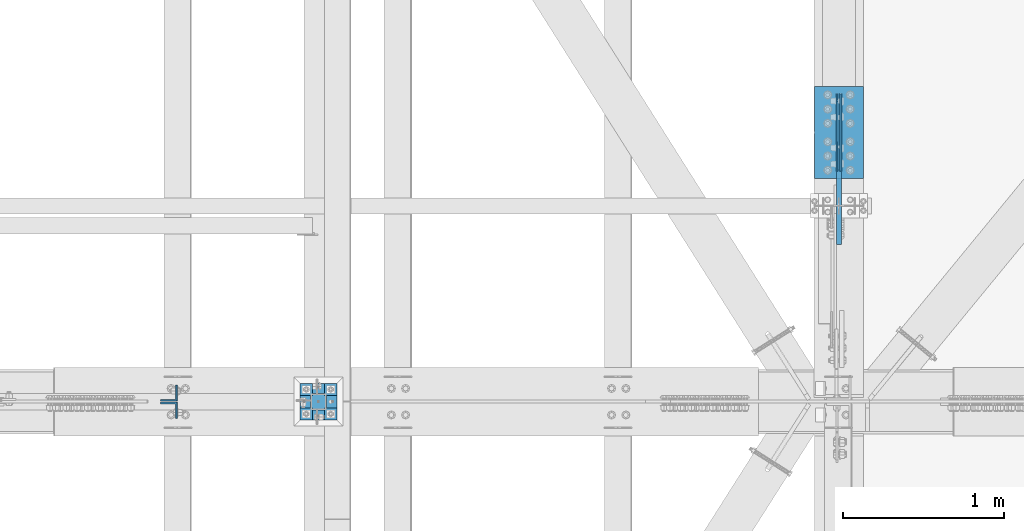
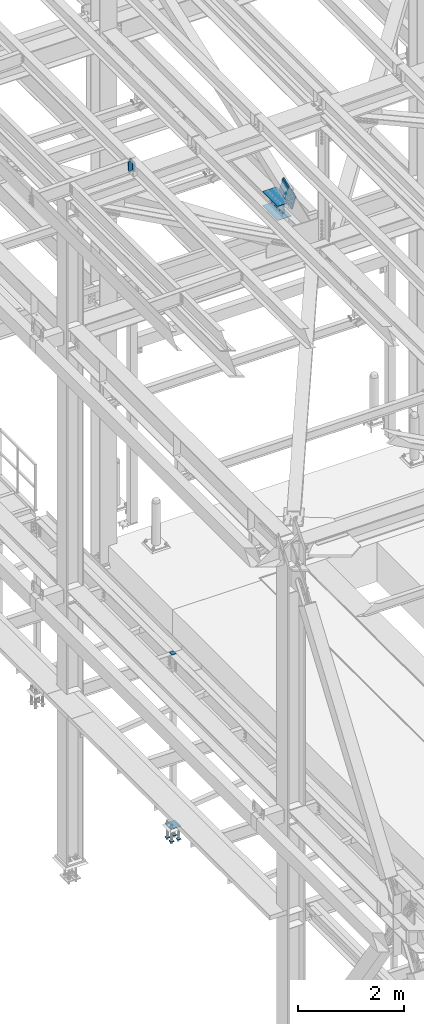
# One storey, part 2405 of 3843: 10 beams, 3 members, 5 elements without a shape of their own.
"""IFC2X3 building model written with IfcOpenShell, lengths in millimetres."""

from ifc_helpers import new_model, si_unit, frame, origin_with_axes, place, context, subcontext, project, spatial, faceted_brep, material, type_object, element, aggregate, save


model = new_model("IFC2X3")

# Units and contexts
model_context = context("Model", 3, precision=1e-05, world=origin_with_axes())
body_context = subcontext(model_context, "Body", "Model", "MODEL_VIEW")
ifc_project = project(units=[si_unit("LENGTHUNIT", "METRE", prefix="MILLI"), si_unit("AREAUNIT", "SQUARE_METRE"), si_unit("VOLUMEUNIT", "CUBIC_METRE"), si_unit("MASSUNIT", "GRAM", prefix="KILO"), si_unit("TIMEUNIT", "SECOND"), si_unit("PLANEANGLEUNIT", "RADIAN"), si_unit("SOLIDANGLEUNIT", "STERADIAN"), si_unit("THERMODYNAMICTEMPERATUREUNIT", "DEGREE_CELSIUS"), si_unit("LUMINOUSINTENSITYUNIT", "LUMEN")], contexts=[model_context])

# Site, building, storey
site_placement = place(None, origin_with_axes())
site = spatial("IfcSite", under=ifc_project, at=site_placement, CompositionType="ELEMENT")
building_placement = place(site_placement, origin_with_axes())
building = spatial("IfcBuilding", under=site, at=building_placement, Name="Undefined", CompositionType="ELEMENT")
storey_placement = place(building_placement, origin_with_axes())
storey = spatial("IfcBuildingStorey", under=building, at=storey_placement, Name="Undefined", CompositionType="ELEMENT", Elevation=0.0)

# Assembly, members
assembly_1_placement = place(storey_placement, origin_with_axes())
assembly_1 = element("IfcElementAssembly", 1, at=assembly_1_placement, inside=storey, Name="BEAM", AssemblyPlace="NOTDEFINED", PredefinedType="RIGID_FRAME")
ifc_material = material(Name="STEEL/A572-50")
member_type_1 = type_object("IfcMemberType", Name="L4X4X3/8", PredefinedType="NOTDEFINED")
member_1_placement = place(assembly_1_placement, frame((37892.6968642126, 84039.0749999523, 45491.3538421112), z_axis=(0.0, 1.0, 0.0), x_axis=(-0.0211520980073474, 0.0, 0.999776269347241)))
member_1 = element("IfcMember", 2, at=member_1_placement, type_object=member_type_1, material=ifc_material, Name="ANGLE", ObjectType="L4X4X3/8", context=body_context, shape_type="Brep", body=[
    faceted_brep([(0.0, 50.8000000000029, -50.8000000000029), (0.0, 50.8000000000029, 50.8000000000029), (228.599999994367, 50.7999999996973, 50.8000000000029), (228.599999994367, 50.7999999996973, -50.8000000000029), (0.0, 41.2750000000015, 50.8000000000029), (228.599999994345, 41.2749999997031, 50.8000000000029), (0.0, 41.2749999999942, -41.2750000000015), (228.599999994345, 41.2749999997031, -41.2750000000015), (0.0, -50.8000000000029, -41.2750000000015), (228.599999994258, -50.8000000001412, -41.2750000000015), (0.0, -50.8000000000029, -50.8000000000029), (228.599999994258, -50.8000000001412, -50.8000000000029)], [[[0, 1, 2, 3]], [[1, 4, 5, 2]], [[4, 6, 7, 5]], [[6, 8, 9, 7]], [[8, 10, 11, 9]], [[10, 0, 3, 11]], [[5, 7, 9, 11, 3, 2]], [[10, 8, 6, 4, 1, 0]]]),
])
member_2_placement = place(assembly_1_placement, frame((37887.8614946073, 83931.1250000477, 45719.9026972787), z_axis=(0.0, -1.0, 0.0), x_axis=(0.0211520550054438, 0.0, -0.999776270257025)))
member_2 = element("IfcMember", 3, at=member_2_placement, type_object=member_type_1, material=ifc_material, Name="ANGLE", ObjectType="L4X4X3/8", context=body_context, shape_type="Brep", body=[
    faceted_brep([(0.0, 50.8000000000029, -50.8000000000029), (0.0, 50.8000000000029, 50.8000000000029), (228.599999994367, 50.7999999996973, 50.8000000000029), (228.599999994367, 50.7999999996973, -50.8000000000029), (0.0, 41.2750000000015, 50.8000000000029), (228.599999994345, 41.2749999997031, 50.8000000000029), (0.0, 41.2749999999942, -41.2750000000015), (228.599999994345, 41.2749999997031, -41.2750000000015), (0.0, -50.8000000000029, -41.2750000000015), (228.599999994258, -50.8000000001412, -41.2750000000015), (0.0, -50.8000000000029, -50.8000000000029), (228.599999994258, -50.8000000001412, -50.8000000000029)], [[[0, 1, 2, 3]], [[1, 4, 5, 2]], [[4, 6, 7, 5]], [[6, 8, 9, 7]], [[8, 10, 11, 9]], [[10, 0, 3, 11]], [[5, 7, 9, 11, 3, 2]], [[10, 8, 6, 4, 1, 0]]]),
])
aggregate(assembly_1, [member_1, member_2])

# Assembly, beams
assembly_2_placement = place(storey_placement, origin_with_axes())
assembly_2 = element("IfcElementAssembly", 4, at=assembly_2_placement, inside=storey, Name="BEAM", AssemblyPlace="NOTDEFINED", PredefinedType="RIGID_FRAME")
beam_type_1 = type_object("IfcBeamType", PredefinedType="NOTDEFINED")
beam_1_placement = place(assembly_2_placement, frame((42073.5125, 85420.2000125336, 42248.7356111364), z_axis=(0.0, 0.000321673000085866, 0.999999948263239), x_axis=(0.0, 0.999999948263239, -0.000321673000078448)))
beam_1 = element("IfcBeam", 5, at=beam_1_placement, type_object=beam_type_1, material=ifc_material, Name="PLATE", context=body_context, shape_type="Brep", body=[
    faceted_brep([(-4.65661287307739e-10, 4.76249999999709, -88.9000000002779), (0.0, 4.76249999999709, 88.9000015258789), (482.600000007384, 4.76249999999709, 88.9000000010856), (482.60000000638, 4.76249999999709, -88.8999999994776), (0.0, -4.76249999999709, 88.9000015258789), (482.600000007384, -4.76249999999709, 88.9000000010856), (-4.65661287307739e-10, -4.76249999999709, -88.9000000002779), (482.60000000638, -4.76249999999709, -88.8999999994776)], [[[0, 1, 2, 3]], [[1, 4, 5, 2]], [[4, 6, 7, 5]], [[6, 0, 3, 7]], [[5, 7, 3, 2]], [[6, 4, 1, 0]]]),
])
beam_2_placement = place(assembly_2_placement, frame((42051.2875, 85420.2000125336, 42248.7356111364), z_axis=(0.0, 0.000321673000085866, 0.999999948263239), x_axis=(0.0, 0.999999948263239, -0.000321673000078448)))
beam_2 = element("IfcBeam", 6, at=beam_2_placement, type_object=beam_type_1, material=ifc_material, Name="PLATE", context=body_context, shape_type="Brep", body=[
    faceted_brep([(-4.65661287307739e-10, 4.76249999999709, -88.9000000002779), (0.0, 4.76249999999709, 88.9000015258789), (482.600000007384, 4.76249999999709, 88.9000000010856), (482.60000000638, 4.76249999999709, -88.8999999994776), (0.0, -4.76249999999709, 88.9000015258789), (482.600000007384, -4.76249999999709, 88.9000000010856), (-4.65661287307739e-10, -4.76249999999709, -88.9000000002779), (482.60000000638, -4.76249999999709, -88.8999999994776)], [[[0, 1, 2, 3]], [[1, 4, 5, 2]], [[4, 6, 7, 5]], [[6, 0, 3, 7]], [[5, 7, 3, 2]], [[6, 4, 1, 0]]]),
])
beam_type_2 = type_object("IfcBeamType", PredefinedType="NOTDEFINED")
beam_3_placement = place(assembly_2_placement, frame((42062.4, 85375.6979279318, 42086.8249178814), z_axis=(1.0, 0.0, 0.0), x_axis=(0.0, 0.999999948263239, -0.000321673000078448)))
beam_3 = element("IfcBeam", 7, at=beam_3_placement, type_object=beam_type_2, material=ifc_material, Name="PLATE", context=body_context, shape_type="Brep", body=[
    faceted_brep([(2.91038304567337e-11, 4.76250000001892, -152.400000000001), (2.91038304567337e-11, 4.76250000001892, 152.400000000001), (571.500000008222, 4.76250000096479, 152.400000000001), (571.500000008222, 4.76250000096479, -152.400000000001), (-2.91038304567337e-11, -4.76250000001164, 152.400000000001), (571.500000008164, -4.76249999906577, 152.400000000001), (-2.91038304567337e-11, -4.76250000001164, -152.400000000001), (571.500000008164, -4.76249999906577, -152.400000000001)], [[[0, 1, 2, 3]], [[1, 4, 5, 2]], [[4, 6, 7, 5]], [[6, 0, 3, 7]], [[5, 7, 3, 2]], [[6, 4, 1, 0]]]),
])
beam_4_placement = place(assembly_2_placement, frame((42062.4, 85375.8021017318, 42410.6749011208), z_axis=(1.0, 0.0, 0.0), x_axis=(0.0, 0.999999948263239, -0.000321673000078448)))
beam_4 = element("IfcBeam", 8, at=beam_4_placement, type_object=beam_type_2, material=ifc_material, Name="PLATE", context=body_context, shape_type="Brep", body=[
    faceted_brep([(2.91038304567337e-11, 4.76250000001892, -152.400000000001), (2.91038304567337e-11, 4.76250000001892, 152.400000000001), (571.500000008222, 4.76250000096479, 152.400000000001), (571.500000008222, 4.76250000096479, -152.400000000001), (-2.91038304567337e-11, -4.76250000001164, 152.400000000001), (571.500000008164, -4.76249999906577, 152.400000000001), (-2.91038304567337e-11, -4.76250000001164, -152.400000000001), (571.500000008164, -4.76249999906577, -152.400000000001)], [[[0, 1, 2, 3]], [[1, 4, 5, 2]], [[4, 6, 7, 5]], [[6, 0, 3, 7]], [[5, 7, 3, 2]], [[6, 4, 1, 0]]]),
])
aggregate(assembly_2, [beam_1, beam_3, beam_4, beam_2])

# Assembly, member
assembly_3_placement = place(storey_placement, origin_with_axes())
assembly_3 = element("IfcElementAssembly", 9, at=assembly_3_placement, inside=storey, AssemblyPlace="NOTDEFINED", PredefinedType="RIGID_FRAME")
member_type_2 = type_object("IfcMemberType", PredefinedType="NOTDEFINED")
member_3_placement = place(assembly_3_placement, frame((42062.4, 85030.1293786808, 42641.7074003114), z_axis=(0.0, 0.351612257950095, -0.936145725867098), x_axis=(0.0, 0.936145725867102, 0.351612257950085)))
member_3 = element("IfcMember", 10, at=member_3_placement, type_object=member_type_2, material=ifc_material, Name="PLATE", context=body_context, shape_type="Brep", body=[
    faceted_brep([(3.56521923094988e-10, 15.875, -190.500000000146), (-3.61978891305625e-10, 15.875, 190.500000000153), (495.299999995012, 15.875, 190.500000001084), (495.299999995726, 15.875, -190.499999999221), (-3.61978891305625e-10, -15.875, 190.500000000153), (495.299999995012, -15.875, 190.500000001084), (3.56521923094988e-10, -15.875, -190.500000000146), (495.299999995726, -15.875, -190.499999999221)], [[[0, 1, 2, 3]], [[1, 4, 5, 2]], [[4, 6, 7, 5]], [[6, 0, 3, 7]], [[5, 7, 3, 2]], [[6, 4, 1, 0]]]),
])
aggregate(assembly_3, [member_3])

# Assembly, beam
assembly_4_placement = place(storey_placement, origin_with_axes())
assembly_4 = element("IfcElementAssembly", 11, at=assembly_4_placement, inside=storey, Name="COLUMN", AssemblyPlace="NOTDEFINED", PredefinedType="RIGID_FRAME")
beam_type_3 = type_object("IfcBeamType", PredefinedType="NOTDEFINED")
beam_5_placement = place(assembly_4_placement, frame((38871.525, 83985.1, 34029.65), z_axis=(0.0, 1.0, 0.0), x_axis=(-1.0, 0.0, 0.0)))
beam_5 = element("IfcBeam", 12, at=beam_5_placement, type_object=beam_type_3, material=ifc_material, Name="PLATE", context=body_context, shape_type="Brep", body=[
    faceted_brep([(0.0, 6.34999999999854, -50.8000000000029), (0.0, 6.35000000000582, 50.7999992361001), (101.600000000006, 6.34999999999854, 50.8000000000029), (101.600000000006, 6.34999999999854, -50.8000000000029), (0.0, -6.35000000000582, 50.7999992361001), (101.600000000006, -6.34999999999854, 50.8000000000029), (0.0, -6.34999999999854, -50.8000000000029), (101.600000000006, -6.34999999999854, -50.8000000000029)], [[[0, 1, 2, 3]], [[1, 4, 5, 2]], [[4, 6, 7, 5]], [[6, 0, 3, 7]], [[5, 7, 3, 2]], [[6, 4, 1, 0]]]),
])
aggregate(assembly_4, [beam_5])

# Assembly, beams
assembly_5_placement = place(storey_placement, origin_with_axes())
assembly_5 = element("IfcElementAssembly", 13, at=assembly_5_placement, inside=storey, Name="TEMPLATE", AssemblyPlace="NOTDEFINED", PredefinedType="RIGID_FRAME")
beam_type_4 = type_object("IfcBeamType", PredefinedType="NOTDEFINED")
beam_6_placement = place(assembly_5_placement, frame((38935.025, 83908.9, 29762.45), z_axis=(0.0, 1.0, 0.0), x_axis=(-1.0, 0.0, 0.0)))
beam_6 = element("IfcBeam", 14, at=beam_6_placement, type_object=beam_type_4, material=ifc_material, context=body_context, shape_type="Brep", body=[
    faceted_brep([(0.0, 6.34999999999854, -38.1000000000058), (0.0, 6.34999999999854, 38.0999984741211), (76.1999999999971, 6.34999999999854, 38.1000000000058), (76.1999999999971, 6.34999999999854, -38.1000000000058), (0.0, -6.34999999999854, 38.0999984741211), (76.1999999999971, -6.34999999999854, 38.1000000000058), (0.0, -6.34999999999854, -38.1000000000058), (76.1999999999971, -6.34999999999854, -38.1000000000058)], [[[0, 1, 2, 3]], [[1, 4, 5, 2]], [[4, 6, 7, 5]], [[6, 0, 3, 7]], [[5, 7, 3, 2]], [[6, 4, 1, 0]]]),
])
beam_7_placement = place(assembly_5_placement, frame((38935.025, 84061.3, 29762.45), z_axis=(0.0, 1.0, 0.0), x_axis=(-1.0, 0.0, 0.0)))
beam_7 = element("IfcBeam", 15, at=beam_7_placement, type_object=beam_type_4, material=ifc_material, context=body_context, shape_type="Brep", body=[
    faceted_brep([(0.0, 6.34999999999854, -38.1000000000058), (0.0, 6.34999999999854, 38.0999984741211), (76.1999999999971, 6.34999999999854, 38.1000000000058), (76.1999999999971, 6.34999999999854, -38.1000000000058), (0.0, -6.34999999999854, 38.0999984741211), (76.1999999999971, -6.34999999999854, 38.1000000000058), (0.0, -6.34999999999854, -38.1000000000058), (76.1999999999971, -6.34999999999854, -38.1000000000058)], [[[0, 1, 2, 3]], [[1, 4, 5, 2]], [[4, 6, 7, 5]], [[6, 0, 3, 7]], [[5, 7, 3, 2]], [[6, 4, 1, 0]]]),
])
beam_8_placement = place(assembly_5_placement, frame((38782.625, 83908.9, 29762.45), z_axis=(0.0, 1.0, 0.0), x_axis=(-1.0, 0.0, 0.0)))
beam_8 = element("IfcBeam", 16, at=beam_8_placement, type_object=beam_type_4, material=ifc_material, context=body_context, shape_type="Brep", body=[
    faceted_brep([(0.0, 6.34999999999854, -38.1000000000058), (0.0, 6.34999999999854, 38.0999984741211), (76.1999999999971, 6.34999999999854, 38.1000000000058), (76.1999999999971, 6.34999999999854, -38.1000000000058), (0.0, -6.34999999999854, 38.0999984741211), (76.1999999999971, -6.34999999999854, 38.1000000000058), (0.0, -6.34999999999854, -38.1000000000058), (76.1999999999971, -6.34999999999854, -38.1000000000058)], [[[0, 1, 2, 3]], [[1, 4, 5, 2]], [[4, 6, 7, 5]], [[6, 0, 3, 7]], [[5, 7, 3, 2]], [[6, 4, 1, 0]]]),
])
beam_9_placement = place(assembly_5_placement, frame((38782.625, 84061.3, 29762.45), z_axis=(0.0, 1.0, 0.0), x_axis=(-1.0, 0.0, 0.0)))
beam_9 = element("IfcBeam", 17, at=beam_9_placement, type_object=beam_type_4, material=ifc_material, context=body_context, shape_type="Brep", body=[
    faceted_brep([(0.0, 6.34999999999854, -38.1000000000058), (0.0, 6.34999999999854, 38.0999984741211), (76.1999999999971, 6.34999999999854, 38.1000000000058), (76.1999999999971, 6.34999999999854, -38.1000000000058), (0.0, -6.34999999999854, 38.0999984741211), (76.1999999999971, -6.34999999999854, 38.1000000000058), (0.0, -6.34999999999854, -38.1000000000058), (76.1999999999971, -6.34999999999854, -38.1000000000058)], [[[0, 1, 2, 3]], [[1, 4, 5, 2]], [[4, 6, 7, 5]], [[6, 0, 3, 7]], [[5, 7, 3, 2]], [[6, 4, 1, 0]]]),
])
beam_type_5 = type_object("IfcBeamType", PredefinedType="NOTDEFINED")
beam_10_placement = place(assembly_5_placement, frame((38935.025, 83985.1, 30062.4875), z_axis=(0.0, -1.0, 0.0), x_axis=(-1.0, 0.0, 0.0)))
beam_10 = element("IfcBeam", 18, at=beam_10_placement, type_object=beam_type_5, material=ifc_material, Name="TEMPLATE", context=body_context, shape_type="Brep", body=[
    faceted_brep([(0.0, 1.58750000000146, -114.300000000003), (0.0, 1.58750000000146, 114.300000000003), (228.600000000006, 1.58750000000146, 114.300000000003), (228.600000000006, 1.58750000000146, -114.300000000003), (0.0, -1.58750000000146, 114.300000000003), (228.600000000006, -1.58750000000146, 114.300000000003), (0.0, -1.58750000000146, -114.300000000003), (228.600000000006, -1.58750000000146, -114.300000000003)], [[[0, 1, 2, 3]], [[1, 4, 5, 2]], [[4, 6, 7, 5]], [[6, 0, 3, 7]], [[5, 7, 3, 2]], [[6, 4, 1, 0]]]),
])
aggregate(assembly_5, [beam_6, beam_7, beam_8, beam_9, beam_10])

save(model, "model.ifc")
